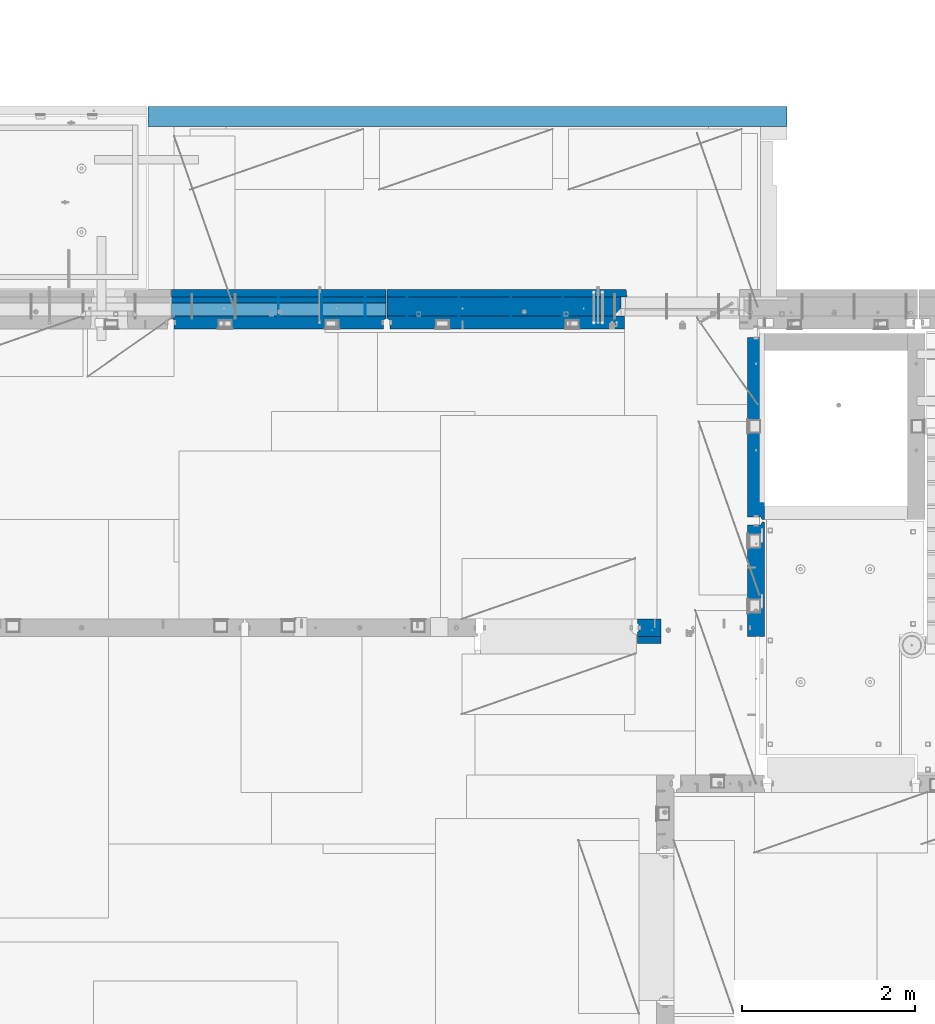
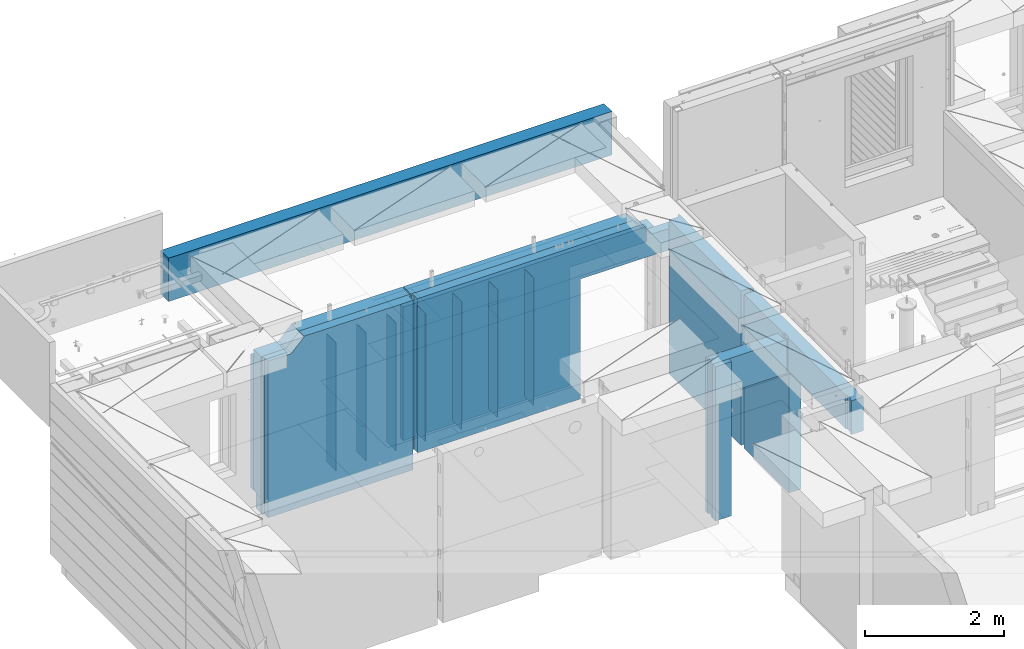
# One storey, part 216 of 325: 19 walls, 6 elements without a shape of their own.
"""IFC2X3 building model written with IfcOpenShell, lengths in millimetres."""

from ifc_helpers import new_model, si_unit, frame, origin_with_axes, place, context, subcontext, project, spatial, faceted_brep, material, type_object, element, aggregate, save


model = new_model("IFC2X3")

# Units and contexts
model_context = context("Model", 3, precision=1e-05, world=origin_with_axes())
body_context = subcontext(model_context, "Body", "Model", "MODEL_VIEW")
ifc_project = project(units=[si_unit("LENGTHUNIT", "METRE", prefix="MILLI"), si_unit("AREAUNIT", "SQUARE_METRE"), si_unit("VOLUMEUNIT", "CUBIC_METRE"), si_unit("MASSUNIT", "GRAM", prefix="KILO"), si_unit("TIMEUNIT", "SECOND"), si_unit("PLANEANGLEUNIT", "RADIAN"), si_unit("SOLIDANGLEUNIT", "STERADIAN"), si_unit("THERMODYNAMICTEMPERATUREUNIT", "DEGREE_CELSIUS"), si_unit("LUMINOUSINTENSITYUNIT", "LUMEN")], contexts=[model_context])

# Site, building, storey
site_placement = place(None, origin_with_axes())
site = spatial("IfcSite", under=ifc_project, at=site_placement, CompositionType="ELEMENT")
building_placement = place(site_placement, origin_with_axes())
building = spatial("IfcBuilding", under=site, at=building_placement, CompositionType="ELEMENT")
storey_placement = place(building_placement, origin_with_axes())
storey = spatial("IfcBuildingStorey", under=building, at=storey_placement, Name="1", CompositionType="ELEMENT", Elevation=0.0)

# Assembly, wall
assembly_1_placement = place(storey_placement, origin_with_axes())
assembly_1 = element("IfcElementAssembly", 1, at=assembly_1_placement, inside=storey, AssemblyPlace="NOTDEFINED", PredefinedType="REINFORCEMENT_UNIT")
ifc_material_1 = material(Name="CONCRETE/C25/30")
wall_type_1 = type_object("IfcWallType", PredefinedType="NOTDEFINED")
wall_1_placement = place(assembly_1_placement, frame((17710.0, 18214.9992663657, 83112.5), z_axis=(0.0, 0.0, 1.0), x_axis=(0.0, 1.0, 0.0)))
wall_1 = element("IfcWall", 2, at=wall_1_placement, type_object=wall_type_1, material=ifc_material_1, context=body_context, shape_type="Brep", body=[
    faceted_brep([(2120.00073363433, -57.0000000000036, 1357.5), (2120.00073363433, -57.0000000000036, -1357.5), (2120.00073363433, 100.0, -1357.5), (2120.00073363433, 100.0, 1357.5), (2165.00073363433, -70.0000000000036, 1357.5), (2165.00073363433, -70.0000000000036, -1357.5), (45.0, 100.0, 1357.5), (45.0, 100.0, -1357.5), (45.0, -57.0, -1357.5), (45.0, -57.0, 1357.5), (15.0, -70.0, 1357.5), (15.0, -70.0000000000036, -1357.5), (15.0, -100.0, -1357.5), (15.0, -100.0, 1357.5), (2165.00073363433, -100.0, -1357.5), (2165.00073363433, -100.0, 1357.5)], [[[0, 1, 2, 3]], [[4, 5, 1, 0]], [[6, 7, 8, 9]], [[10, 9, 8, 11]], [[12, 13, 10, 11]], [[13, 12, 14, 15]], [[3, 6, 9, 10, 13, 15, 4, 0]], [[7, 6, 3, 2]], [[14, 12, 11, 8, 7, 2, 1, 5]], [[15, 14, 5, 4]]]),
])
aggregate(assembly_1, [wall_1])

assembly_2_placement = place(storey_placement, origin_with_axes())
assembly_2 = element("IfcElementAssembly", 3, at=assembly_2_placement, inside=storey, AssemblyPlace="NOTDEFINED", PredefinedType="REINFORCEMENT_UNIT")
wall_2_placement = place(assembly_2_placement, frame((17710.0, 15080.0, 83112.5), z_axis=(0.0, 0.0, 1.0), x_axis=(0.0, 1.0, 0.0)))
wall_2 = element("IfcWall", 4, at=wall_2_placement, type_object=wall_type_1, material=ifc_material_1, context=body_context, shape_type="Brep", body=[
    faceted_brep([(1835.0, 100.0, 762.5), (1848.00000041054, 79.9999993903439, 762.5), (1951.9999991369, 80.0000000823711, 762.5), (1965.00000368528, 99.9999997455598, 762.5), (1848.00000041054, 79.9999993903439, 1357.5), (1835.0, 100.0, 1357.5), (1951.9999991369, 80.0000000823711, 1357.5), (1965.00000368528, 100.0, 1357.5), (1800.00323852539, -100.0, 762.5), (1800.00323852539, 100.0, 762.5), (1800.00323852539, 100.0, -1357.5), (1800.00323852539, -100.0, -1357.5), (3119.99926636568, -100.0, -1357.5), (3089.99926636568, 100.0, -1357.5), (3089.99926636568, -57.0, -1357.5), (3119.99926636568, -70.0, -1357.5), (3089.99926636568, -57.0, 1357.5), (3089.99926636568, 100.0, 1357.5), (3119.99926636568, -70.0, 1357.5), (3119.99926636568, -100.0, 1357.5), (164.999999999998, -99.9991455078125, 1357.5), (164.999999999998, -100.0, 762.5), (152.000000457019, -79.9991466091124, 1357.5), (152.000000457019, -79.9991466091124, 762.5), (47.9997742438973, -79.9991481948964, 1357.5), (47.9997742438973, -79.9991481948964, 762.5), (34.9997701872417, -100.0, 1357.5), (34.9997701872417, -100.0, 762.5), (0.0, -100.0, 1357.5), (0.0, -100.0, 762.5), (0.0, 100.0, 762.5), (35.0, 100.0, 762.5), (48.0, 80.0, 762.5), (152.0, 80.0, 762.5), (164.999999999996, 100.0, 762.5), (0.0, 100.0, 1357.5), (35.0, 100.0, 1357.5), (48.0, 80.0, 1357.5), (152.0, 80.0, 1357.5), (164.999999999996, 100.0, 1357.5)], [[[0, 1, 2, 3]], [[4, 1, 0, 5]], [[6, 2, 1, 4]], [[7, 3, 2, 6]], [[8, 9, 10, 11]], [[12, 11, 10, 13, 14, 15]], [[16, 14, 13, 17]], [[18, 15, 14, 16]], [[19, 12, 15, 18]], [[8, 11, 12, 19, 20, 21]], [[20, 22, 23, 21]], [[24, 25, 23, 22]], [[26, 27, 25, 24]], [[28, 29, 27, 26]], [[9, 8, 21, 23, 25, 27, 29, 30, 31, 32, 33, 34]], [[28, 35, 30, 29]], [[30, 35, 36, 31]], [[37, 32, 31, 36]], [[38, 33, 32, 37]], [[39, 34, 33, 38]], [[17, 13, 10, 9, 34, 39, 5, 0, 3, 7]], [[5, 39, 38, 37, 36, 35, 28, 26, 24, 22, 20, 19, 18, 16, 17, 7, 6, 4]]]),
])
aggregate(assembly_2, [wall_2])

assembly_3_placement = place(storey_placement, origin_with_axes())
assembly_3 = element("IfcElementAssembly", 5, at=assembly_3_placement, inside=storey, AssemblyPlace="NOTDEFINED", PredefinedType="REINFORCEMENT_UNIT")
ifc_material_2 = material(Name="CONCRETE/C30/37")
wall_3_placement = place(assembly_3_placement, frame((16339.9991042544, 16980.0, 83112.5), z_axis=(0.0, 0.0, 1.0), x_axis=(1.0, 0.0, 0.0)))
wall_3 = element("IfcWall", 6, at=wall_3_placement, type_object=wall_type_1, material=ifc_material_2, context=body_context, shape_type="Brep", body=[
    faceted_brep([(20.0000412533955, -36.0000000000036, 1357.5), (20.0000412533955, -36.0000000000036, -1357.5), (0.0, -50.0, -1357.5), (0.0, -50.0, 1357.5), (20.0000412533955, 35.9999999999964, 1357.5), (20.0000412533955, 35.9999999999964, -1357.5), (0.0, 50.0, 1357.5), (0.0, 50.0, -1357.5), (270.000743318027, 99.9999994302016, 762.5), (270.000743318027, -100.0, 762.5), (270.000743318027, -100.0, -1357.5), (270.000743318027, 100.0, -1357.5), (0.0, 100.0, -1357.5), (0.0, 100.0, 1357.5), (1205.00089558427, 100.0, 1357.5), (1205.00089558427, 99.9999953150655, 762.5), (1240.0, -72.1666661360759, 1357.5), (1240.0, -100.0, 1357.5), (1240.0, -100.0, 762.5), (1240.00086538834, -72.1666661360759, 762.5), (1205.00089574558, -57.0, 1357.5), (1205.00089574558, -57.0, 762.5), (0.0, -100.0, 1357.5), (0.0, -100.0, -1357.5)], [[[0, 1, 2, 3]], [[4, 5, 1, 0]], [[6, 7, 5, 4]], [[8, 9, 10, 11]], [[11, 12, 13, 14, 15, 8]], [[16, 17, 18, 19]], [[20, 16, 19, 21]], [[14, 20, 21, 15]], [[19, 18, 9, 8, 15, 21]], [[17, 22, 23, 10, 9, 18]], [[23, 22, 3, 2]], [[12, 11, 10, 23, 2, 1, 5, 7]], [[13, 12, 7, 6]], [[3, 22, 17, 16, 20, 14, 13, 6, 4, 0]]]),
])

assembly_4_placement = place(storey_placement, origin_with_axes())
assembly_4 = element("IfcElementAssembly", 7, at=assembly_4_placement, inside=storey, AssemblyPlace="NOTDEFINED", PredefinedType="REINFORCEMENT_UNIT")
wall_type_2 = type_object("IfcWallType", PredefinedType="NOTDEFINED")
wall_4_placement = place(assembly_4_placement, frame((13450.0, 20504.9951872276, 83112.5), z_axis=(0.0, 0.0, 1.0), x_axis=(1.0, 0.0, 0.0)))
wall_4 = element("IfcWall", 8, at=wall_4_placement, type_object=wall_type_2, material=ifc_material_1, context=body_context, shape_type="Brep", body=[
    faceted_brep([(4334.0, -50.8403744551615, 1117.5), (4334.0, -50.8403744551615, 1067.5), (4334.0, 49.1596255448385, 1067.5), (4334.0, 49.1596255448385, 1117.5), (4280.0, -50.8403744551615, 1117.5), (4280.0, 49.1596255448385, 1117.5), (4280.0, -50.8403744551615, 1127.5), (4280.0, 49.1596255448385, 1127.5), (4340.0, -50.8403744551615, 1127.5), (4339.99999999997, -50.8403744551615, 1067.5), (4339.99999999997, 49.1596255448385, 1067.5), (4340.0, 49.1596255448385, 1127.5), (4219.99999584191, -75.0, 748.653846154048), (4232.99999996855, -54.9951871385092, 748.653846154077), (4232.99999996855, -54.9951871385092, 1127.5), (4219.99999584191, -75.0, 1127.5), (4286.99999987311, -54.9951859726425, 748.65384615415), (4286.99999987311, -54.9951859726425, 1127.5), (4300.00000278436, -75.0, 748.65384615415), (4340.0, -75.0, 748.653846154208), (4340.0, -75.0, 1127.5), (4300.00000278436, -74.9970067365539, 1127.5), (4079.99976053389, -75.0, 748.653846153858), (4076.15360668774, 75.0, 748.653846153844), (4340.0, 75.0, 748.653846154208), (4079.99976053389, -75.0, 752.5), (2739.99976053389, -75.0, 752.5), (2743.84591438005, 75.0, 748.653846153844), (2739.99976053389, -75.0, -1357.5), (2743.84591438005, 75.0, -1357.5), (3699.65466308594, -75.0, 1357.5), (3699.65466308594, 75.0, 1357.5), (0.0, 75.0, 1357.5), (0.0, 45.0, 1357.5), (29.9999989126591, 32.0000004547946, 1357.5), (30.0000016637459, -75.0, 1357.5), (0.0, 75.0, -1357.5), (0.0, 45.0, -1357.5), (29.9999989126591, 32.0000004547946, -1357.5), (30.0000016637459, -75.0, -1357.5), (3930.00015258789, -75.0000000000036, 1127.5), (3930.00015258789, 74.9999999999964, 1127.5), (4340.0, 75.0, 1127.5)], [[[0, 1, 2, 3]], [[4, 0, 3, 5]], [[6, 4, 5, 7]], [[8, 9, 1, 0, 4, 6]], [[10, 2, 1, 9]], [[11, 7, 5, 3, 2, 10]], [[12, 13, 14, 15]], [[13, 16, 17, 14]], [[18, 19, 20, 21]], [[16, 18, 21, 17]], [[13, 12, 22, 23, 24, 19, 18, 16]], [[25, 23, 22]], [[26, 27, 23, 25]], [[27, 26, 28, 29]], [[30, 31, 32, 33, 34, 35]], [[32, 36, 37, 33]], [[33, 37, 38, 34]], [[36, 29, 28, 39, 38, 37]], [[34, 38, 39, 35]], [[28, 26, 25, 22, 12, 15, 40, 30, 35, 39]], [[31, 30, 40, 41]], [[24, 23, 27, 29, 36, 32, 31, 41, 42]], [[9, 8, 20, 19, 24, 42, 11, 10]], [[42, 41, 40, 15, 14, 17, 21, 20, 8, 6, 7, 11]]]),
])

assembly_5_placement = place(storey_placement, origin_with_axes())
assembly_5 = element("IfcElementAssembly", 9, at=assembly_5_placement, inside=storey, AssemblyPlace="NOTDEFINED", PredefinedType="REINFORCEMENT_UNIT")
wall_type_3 = type_object("IfcWallType", PredefinedType="NOTDEFINED")
wall_5_placement = place(assembly_5_placement, frame((10960.0, 20504.9951872276, 82977.5), z_axis=(0.0, 0.0, 1.0), x_axis=(1.0, 0.0, 0.0)))
wall_5 = element("IfcWall", 10, at=wall_5_placement, type_object=wall_type_3, material=ifc_material_1, context=body_context, shape_type="Brep", body=[
    faceted_brep([(2444.99999833626, -75.0, 1492.5), (2444.99999833626, -75.0, -1492.5), (2445.00000108732, 32.0000004548419, -1492.5), (2445.00000108732, 32.0000004548419, 1492.5), (2475.0, 45.0, 1492.5), (2475.0, 45.0, -1492.5), (0.0, 75.0, 1262.5), (0.0, 75.0, -1492.5), (0.0, 45.0, -1492.5), (0.0, 45.0, 1262.5), (30.0, 32.0, -1492.5), (30.0, 32.0, 1262.5), (30.0, -75.0, -1492.5), (30.0, -75.0, 1262.5), (415.999985106067, -75.0, 1262.5), (415.999985106067, 75.0, 1262.5), (629.999832518177, -75.0, 1482.16999816895), (629.999832518177, 75.0, 1482.16999816895), (629.999832518177, 75.0, 1492.5), (629.999832518177, -75.0, 1492.5), (2475.0, 75.0, 1492.5), (2475.0, 75.0, -1492.5)], [[[0, 1, 2, 3]], [[4, 3, 2, 5]], [[6, 7, 8, 9]], [[9, 8, 10, 11]], [[11, 10, 12, 13]], [[14, 15, 6, 9, 11, 13]], [[15, 14, 16, 17]], [[18, 17, 16, 19]], [[20, 21, 7, 6, 15, 17, 18]], [[21, 20, 4, 5]], [[1, 12, 10, 8, 7, 21, 5, 2]], [[19, 16, 14, 13, 12, 1, 0]], [[20, 18, 19, 0, 3, 4]]]),
])

# Wall
ifc_material_3 = material(Name="Undefined")
wall_type_4 = type_object("IfcWallType", PredefinedType="NOTDEFINED")
wall_6_placement = place(assembly_4_placement, frame((15480.0002441406, 20549.9951872276, 82940.0), z_axis=(0.0, 0.0, 1.0), x_axis=(0.0, 1.0, 0.0)))
wall_6 = element("IfcWall", 11, at=wall_6_placement, type_object=wall_type_4, material=ifc_material_3, Name="(PD)", context=body_context, shape_type="Brep", body=[
    faceted_brep([(0.0, 5.0, -1125.0), (0.0, 5.0, 1125.0), (280.0, 5.0, 1125.0), (280.0, 5.0, -1125.0), (0.0, -5.0, 1125.0), (280.0, -5.0, 1125.0), (0.0, -5.0, -1125.0), (280.0, -5.0, -1125.0)], [[[0, 1, 2, 3]], [[1, 4, 5, 2]], [[4, 6, 7, 5]], [[6, 0, 3, 7]], [[5, 7, 3, 2]], [[6, 4, 1, 0]]]),
])

wall_7_placement = place(assembly_4_placement, frame((14880.0002441406, 20549.9951872276, 82940.0), z_axis=(0.0, 0.0, 1.0), x_axis=(0.0, 1.0, 0.0)))
wall_7 = element("IfcWall", 12, at=wall_7_placement, type_object=wall_type_4, material=ifc_material_3, Name="(PD)", context=body_context, shape_type="Brep", body=[
    faceted_brep([(0.0, 5.0, -1125.0), (0.0, 5.0, 1125.0), (280.0, 5.0, 1125.0), (280.0, 5.0, -1125.0), (0.0, -5.0, 1125.0), (280.0, -5.0, 1125.0), (0.0, -5.0, -1125.0), (280.0, -5.0, -1125.0)], [[[0, 1, 2, 3]], [[1, 4, 5, 2]], [[4, 6, 7, 5]], [[6, 0, 3, 7]], [[5, 7, 3, 2]], [[6, 4, 1, 0]]]),
])

wall_8_placement = place(assembly_4_placement, frame((14280.0002441406, 20549.9951872276, 82940.0), z_axis=(0.0, 0.0, 1.0), x_axis=(0.0, 1.0, 0.0)))
wall_8 = element("IfcWall", 13, at=wall_8_placement, type_object=wall_type_4, material=ifc_material_3, Name="(PD)", context=body_context, shape_type="Brep", body=[
    faceted_brep([(0.0, 5.0, -1125.0), (0.0, 5.0, 1125.0), (280.0, 5.0, 1125.0), (280.0, 5.0, -1125.0), (0.0, -5.0, 1125.0), (280.0, -5.0, 1125.0), (0.0, -5.0, -1125.0), (280.0, -5.0, -1125.0)], [[[0, 1, 2, 3]], [[1, 4, 5, 2]], [[4, 6, 7, 5]], [[6, 0, 3, 7]], [[5, 7, 3, 2]], [[6, 4, 1, 0]]]),
])

wall_9_placement = place(assembly_4_placement, frame((13680.0002441406, 20549.9951872276, 82940.0), z_axis=(0.0, 0.0, 1.0), x_axis=(0.0, 1.0, 0.0)))
wall_9 = element("IfcWall", 14, at=wall_9_placement, type_object=wall_type_4, material=ifc_material_3, Name="(PD)", context=body_context, shape_type="Brep", body=[
    faceted_brep([(0.0, 5.0, -1125.0), (0.0, 5.0, 1125.0), (280.0, 5.0, 1125.0), (280.0, 5.0, -1125.0), (0.0, -5.0, 1125.0), (280.0, -5.0, 1125.0), (0.0, -5.0, -1125.0), (280.0, -5.0, -1125.0)], [[[0, 1, 2, 3]], [[1, 4, 5, 2]], [[4, 6, 7, 5]], [[6, 0, 3, 7]], [[5, 7, 3, 2]], [[6, 4, 1, 0]]]),
])

wall_10_placement = place(assembly_5_placement, frame((13195.0002441406, 20549.9951872276, 82940.0), z_axis=(0.0, 0.0, 1.0), x_axis=(0.0, 1.0, 0.0)))
wall_10 = element("IfcWall", 15, at=wall_10_placement, type_object=wall_type_4, material=ifc_material_3, Name="(PD)", context=body_context, shape_type="Brep", body=[
    faceted_brep([(0.0, 5.0, -1125.0), (0.0, 5.0, 1125.0), (280.0, 5.0, 1125.0), (280.0, 5.0, -1125.0), (0.0, -5.0, 1125.0), (280.0, -5.0, 1125.0), (0.0, -5.0, -1125.0), (280.0, -5.0, -1125.0)], [[[0, 1, 2, 3]], [[1, 4, 5, 2]], [[4, 6, 7, 5]], [[6, 0, 3, 7]], [[5, 7, 3, 2]], [[6, 4, 1, 0]]]),
])

wall_11_placement = place(assembly_5_placement, frame((12695.0002441406, 20549.9951872276, 82940.0), z_axis=(0.0, 0.0, 1.0), x_axis=(0.0, 1.0, 0.0)))
wall_11 = element("IfcWall", 16, at=wall_11_placement, type_object=wall_type_4, material=ifc_material_3, Name="(PD)", context=body_context, shape_type="Brep", body=[
    faceted_brep([(0.0, 5.0, -1125.0), (0.0, 5.0, 1125.0), (280.0, 5.0, 1125.0), (280.0, 5.0, -1125.0), (0.0, -5.0, 1125.0), (280.0, -5.0, 1125.0), (0.0, -5.0, -1125.0), (280.0, -5.0, -1125.0)], [[[0, 1, 2, 3]], [[1, 4, 5, 2]], [[4, 6, 7, 5]], [[6, 0, 3, 7]], [[5, 7, 3, 2]], [[6, 4, 1, 0]]]),
])

wall_12_placement = place(assembly_5_placement, frame((12195.0002441406, 20549.9951872276, 82940.0), z_axis=(0.0, 0.0, 1.0), x_axis=(0.0, 1.0, 0.0)))
wall_12 = element("IfcWall", 17, at=wall_12_placement, type_object=wall_type_4, material=ifc_material_3, Name="(PD)", context=body_context, shape_type="Brep", body=[
    faceted_brep([(0.0, 5.0, -1125.0), (0.0, 5.0, 1125.0), (280.0, 5.0, 1125.0), (280.0, 5.0, -1125.0), (0.0, -5.0, 1125.0), (280.0, -5.0, 1125.0), (0.0, -5.0, -1125.0), (280.0, -5.0, -1125.0)], [[[0, 1, 2, 3]], [[1, 4, 5, 2]], [[4, 6, 7, 5]], [[6, 0, 3, 7]], [[5, 7, 3, 2]], [[6, 4, 1, 0]]]),
])

ifc_material_4 = material(Name="SPU")
wall_type_5 = type_object("IfcWallType", PredefinedType="NOTDEFINED")
wall_13_placement = place(assembly_5_placement, frame((13435.0, 20654.9951872276, 81620.0000000001), z_axis=(0.0, 0.0, 1.0), x_axis=(-1.0, 3.00000001838171e-08, 0.0)))
wall_13 = element("IfcWall", 18, at=wall_13_placement, type_object=wall_type_5, material=ifc_material_4, context=body_context, shape_type="Brep", body=[
    faceted_brep([(0.0, 75.0, -135.0), (0.0, 75.0, 135.0), (2475.00000000001, 75.0, 135.0), (2475.00000000001, 75.0, -135.0), (0.0, -75.0, 135.0), (2475.00000000001, -75.0, 135.0), (0.0, -75.0, -135.0), (2475.00000000001, -75.0, -135.0)], [[[0, 1, 2, 3]], [[1, 4, 5, 2]], [[4, 6, 7, 5]], [[6, 0, 3, 7]], [[5, 7, 3, 2]], [[6, 4, 1, 0]]]),
])

wall_type_6 = type_object("IfcWallType", PredefinedType="NOTDEFINED")
wall_14_placement = place(assembly_5_placement, frame((10960.0, 20842.4951872276, 82930.0), z_axis=(0.0, 0.0, 1.0), x_axis=(1.0, 0.0, 0.0)))
wall_14 = element("IfcWall", 19, at=wall_14_placement, type_object=wall_type_6, material=ifc_material_2, context=body_context, shape_type="Brep", body=[
    faceted_brep([(2475.0, 42.5, 1060.5), (0.0, 42.5, 1060.5), (0.0, 32.5, 1062.5), (2475.0, 32.5, 1062.5), (0.0, 32.5, 1072.5), (2475.0, 32.5, 1072.5), (2475.0, 42.5, 1074.5), (0.0, 42.5, 1074.5), (2475.0, 42.5, 924.5), (2475.0, 32.5, 922.5), (0.0, 32.5, 922.5), (0.0, 42.5, 924.5), (2475.0, 32.5, 912.5), (0.0, 32.5, 912.5), (2475.0, 42.5, 910.5), (0.0, 42.5, 910.5), (2475.0, 42.5, 774.5), (0.0, 42.5, 774.5), (2475.0, 32.5, 772.5), (0.0, 32.5, 772.5), (2475.0, 32.5, 762.5), (0.0, 32.5, 762.5), (2475.0, 42.5, 760.5), (0.0, 42.5, 760.5), (2475.0, 42.5, 624.5), (0.0, 42.5, 624.5), (2475.0, 32.5, 622.5), (0.0, 32.5, 622.5), (2475.0, 32.5, 612.5), (0.0, 32.5, 612.5), (2475.0, 42.5, 610.5), (0.0, 42.5, 610.5), (2475.0, 42.5, 474.5), (0.0, 42.5, 474.5), (2475.0, 32.5, 472.5), (0.0, 32.5, 472.5), (2475.0, 32.5, 462.5), (0.0, 32.5, 462.5), (2475.0, 42.5, 460.5), (0.0, 42.5, 460.5), (2475.0, 42.5, 324.5), (0.0, 42.5, 324.5), (2475.0, 32.5, 322.5), (0.0, 32.5, 322.5), (2475.0, 32.5, 312.5), (0.0, 32.5, 312.5), (2475.0, 42.5, 310.5), (0.0, 42.5, 310.5), (2475.0, 42.5, 174.5), (0.0, 42.5, 174.5), (2475.0, 32.5, 172.5), (0.0, 32.5, 172.5), (2475.0, 32.5, 162.5), (0.0, 32.5, 162.5), (2475.0, 42.5, 160.5), (0.0, 42.5, 160.5), (2475.0, 42.5, 24.5), (0.0, 42.5, 24.5), (2475.0, 32.5, 22.5), (0.0, 32.5, 22.5), (2475.0, 32.5, 12.5), (0.0, 32.5, 12.5), (2475.0, 42.5, 10.5), (0.0, 42.5, 10.5), (2475.0, 42.5, -125.5), (0.0, 42.5, -125.5), (2475.0, 32.5, -127.5), (0.0, 32.5, -127.5), (2475.0, 32.5, -137.5), (0.0, 32.5, -137.5), (2475.0, 42.5, -139.5), (0.0, 42.5, -139.5), (2475.0, 42.5, -275.5), (0.0, 42.5, -275.5), (2475.0, 32.5, -277.5), (0.0, 32.5, -277.5), (2475.0, 32.5, -287.5), (0.0, 32.5, -287.5), (2475.0, 42.5, -289.5), (0.0, 42.5, -289.5), (2475.0, 42.5, -425.5), (0.0, 42.5, -425.5), (2475.0, 32.5, -427.5), (0.0, 32.5, -427.5), (2475.0, 32.5, -437.5), (0.0, 32.5, -437.5), (2475.0, 42.5, -439.5), (0.0, 42.5, -439.5), (2475.0, 42.5, -575.5), (0.0, 42.5, -575.5), (2475.0, 32.5, -577.5), (0.0, 32.5, -577.5), (2475.0, 32.5, -587.5), (0.0, 32.5, -587.5), (2475.0, 42.5, -589.5), (0.0, 42.5, -589.5), (2475.0, 42.5, -725.5), (0.0, 42.5, -725.5), (2475.0, 32.5, -727.5), (0.0, 32.5, -727.5), (2475.0, 32.5, -737.5), (0.0, 32.5, -737.5), (2475.0, 42.5, -739.5), (0.0, 42.5, -739.5), (2475.0, 42.5, -875.5), (0.0, 42.5, -875.5), (2475.0, 32.5, -877.5), (0.0, 32.5, -877.5), (2475.0, 32.5, -887.5), (0.0, 32.5, -887.5), (2475.0, 42.5, -889.5), (0.0, 42.5, -889.5), (2475.0, 42.5, -1025.5), (0.0, 42.5, -1025.5), (2475.0, 32.5, -1027.5), (0.0, 32.5, -1027.5), (2475.0, 32.5, -1037.5), (0.0, 32.5, -1037.5), (2475.0, 42.5, -1039.5), (0.0, 42.5, -1039.5), (2475.0, 42.5, -1175.0), (0.0, 42.5, -1175.0), (0.0, -42.5, -1175.0), (2475.0, -42.5, -1175.0), (0.0, -42.5, 1175.0), (2475.0, -42.5, 1175.0), (0.0, 42.5, 1175.0), (2475.0, 42.5, 1175.0)], [[[0, 1, 2, 3]], [[3, 2, 4, 5]], [[6, 5, 4, 7]], [[8, 9, 10, 11]], [[12, 13, 10, 9]], [[14, 15, 13, 12]], [[16, 17, 15, 14]], [[16, 18, 19, 17]], [[20, 21, 19, 18]], [[22, 23, 21, 20]], [[24, 25, 23, 22]], [[24, 26, 27, 25]], [[28, 29, 27, 26]], [[30, 31, 29, 28]], [[32, 33, 31, 30]], [[32, 34, 35, 33]], [[36, 37, 35, 34]], [[38, 39, 37, 36]], [[40, 41, 39, 38]], [[40, 42, 43, 41]], [[44, 45, 43, 42]], [[46, 47, 45, 44]], [[48, 49, 47, 46]], [[48, 50, 51, 49]], [[52, 53, 51, 50]], [[54, 55, 53, 52]], [[56, 57, 55, 54]], [[56, 58, 59, 57]], [[60, 61, 59, 58]], [[62, 63, 61, 60]], [[64, 65, 63, 62]], [[64, 66, 67, 65]], [[68, 69, 67, 66]], [[70, 71, 69, 68]], [[72, 73, 71, 70]], [[72, 74, 75, 73]], [[76, 77, 75, 74]], [[78, 79, 77, 76]], [[80, 81, 79, 78]], [[80, 82, 83, 81]], [[84, 85, 83, 82]], [[86, 87, 85, 84]], [[88, 89, 87, 86]], [[88, 90, 91, 89]], [[92, 93, 91, 90]], [[94, 95, 93, 92]], [[96, 97, 95, 94]], [[96, 98, 99, 97]], [[100, 101, 99, 98]], [[102, 103, 101, 100]], [[104, 105, 103, 102]], [[104, 106, 107, 105]], [[108, 109, 107, 106]], [[110, 111, 109, 108]], [[112, 113, 111, 110]], [[112, 114, 115, 113]], [[116, 117, 115, 114]], [[118, 119, 117, 116]], [[120, 121, 119, 118]], [[122, 121, 120, 123]], [[124, 122, 123, 125]], [[126, 124, 125, 127]], [[126, 127, 6, 7]], [[2, 1, 11, 10, 13, 15, 17, 19, 21, 23, 25, 27, 29, 31, 33, 35, 37, 39, 41, 43, 45, 47, 49, 51, 53, 55, 57, 59, 61, 63, 65, 67, 69, 71, 73, 75, 77, 79, 81, 83, 85, 87, 89, 91, 93, 95, 97, 99, 101, 103, 105, 107, 109, 111, 113, 115, 117, 119, 121, 122, 124, 126, 7, 4]], [[8, 11, 1, 0]], [[127, 125, 123, 120, 118, 116, 114, 112, 110, 108, 106, 104, 102, 100, 98, 96, 94, 92, 90, 88, 86, 84, 82, 80, 78, 76, 74, 72, 70, 68, 66, 64, 62, 60, 58, 56, 54, 52, 50, 48, 46, 44, 42, 40, 38, 36, 34, 32, 30, 28, 26, 24, 22, 20, 18, 16, 14, 12, 9, 8, 0, 3, 5, 6]]]),
])

wall_15_placement = place(assembly_4_placement, frame((13450.0, 20842.4951872276, 82930.0), z_axis=(0.0, 0.0, 1.0), x_axis=(1.0, 0.0, 0.0)))
wall_15 = element("IfcWall", 20, at=wall_15_placement, type_object=wall_type_6, material=ifc_material_2, context=body_context, shape_type="Brep", body=[
    faceted_brep([(2245.40315796376, -7.5, 162.496287248374), (2245.40315796376, -7.5, 472.496287248374), (2625.40315796376, -7.5, 472.496287248374), (2625.40315796376, -7.5, 162.496287248374), (2245.40315796376, 32.5000000000036, 162.5), (2625.40315796376, 32.5000000000036, 162.5), (2245.40315796376, 42.5, 460.5), (2245.40315796376, 32.5000000000036, 462.5), (2245.40315796376, 32.5000000000036, 472.5), (2245.40315796376, 32.5000000000036, 172.5), (2245.40315796376, 42.5, 174.5), (2245.40315796376, 42.5, 310.5), (2245.40315796376, 32.5000000000036, 312.5), (2245.40315796376, 32.5000000000036, 322.5), (2245.40315796376, 42.5, 324.5), (2625.40315796376, 32.5000000000036, 472.5), (2625.40315796376, 42.5, 460.5), (2625.40315796376, 42.5, 324.5), (2625.40315796376, 32.5000000000036, 322.5), (2625.40315796376, 32.5000000000036, 312.5), (2625.40315796376, 42.5, 310.5), (2625.40315796376, 42.5, 174.5), (2625.40315796376, 32.5000000000036, 172.5), (2625.40315796376, 32.5000000000036, 462.5), (2761.17429139664, 32.5000000000036, 762.5), (0.0, 32.5, 762.5), (0.0, 32.5, 772.5), (2761.17429044831, 32.5000000000036, 772.5), (2759.99770171037, 42.5, 760.5), (0.0, 42.5, 760.5), (2759.99770171037, 42.5, 624.5), (0.0, 42.5, 624.5), (2761.17430123561, 32.5000000000036, 622.5), (0.0, 32.5, 622.5), (2761.17430218357, 32.5000000000036, 612.5), (0.0, 32.5, 612.5), (2759.99770171037, 42.5, 610.5), (0.0, 42.5, 610.5), (2759.99770171037, 42.5, 474.5), (0.0, 42.5, 474.5), (0.0, 42.5, 1175.0), (4055.0, 42.5, 1175.0), (4055.0, 42.5000000000036, 1074.5), (0.0, 42.5, 1074.5), (0.0, -42.5, 1175.0), (4055.0, -42.5, 1175.0), (2759.99770171037, 42.5, 24.5), (0.0, 42.5, 24.5), (0.0, 42.5, 160.5), (2759.99770171037, 42.5, 160.5), (2761.17434651022, 32.5000000000036, 22.5), (0.0, 32.5, 22.5), (2761.17434745667, 32.5000000000036, 12.5), (0.0, 32.5, 12.5), (2759.99770171037, 42.5, 10.5), (0.0, 42.5, 10.5), (2759.99770171037, 42.5, -125.5), (0.0, 42.5, -125.5), (2761.17435870931, 32.5000000000036, -127.5), (0.0, 32.5, -127.5), (2761.17435965538, 32.5000000000036, -137.5), (0.0, 32.5, -137.5), (2759.99770171037, 42.5, -139.5), (0.0, 42.5, -139.5), (2759.99770171037, 42.5, -275.5), (0.0, 42.5, -275.5), (2761.1743715296, 32.5000000000036, -277.5), (0.0, 32.5, -277.5), (2761.1743724753, 32.5000000000036, -287.5), (0.0, 32.5, -287.5), (2759.99770171037, 42.5, -289.5), (0.0, 42.5, -289.5), (2759.99770171037, 42.5, -425.5), (0.0, 42.5, -425.5), (2761.17438525404, 32.5000000000036, -427.5), (0.0, 32.5, -427.5), (2761.17438619936, 32.5000000000036, -437.5), (0.0, 32.5, -437.5), (2759.99770171037, 42.5, -439.5), (0.0, 42.5, -439.5), (2759.99770171037, 42.5, -575.5), (0.0, 42.5, -575.5), (2761.17440038521, 32.5000000000036, -577.5), (0.0, 32.5, -577.5), (2761.17440133016, 32.5000000000036, -587.5), (0.0, 32.5, -587.5), (2759.99770171037, 42.5, -589.5), (0.0, 42.5, -589.5), (2759.99770171037, 42.5, -725.5), (0.0, 42.5, -725.5), (2761.17441792735, 32.5000000000036, -727.5), (0.0, 32.5, -727.5), (2761.17441887192, 32.5000000000036, -737.5), (0.0, 32.5, -737.5), (2759.99770171037, 42.5, -739.5), (0.0, 42.5, -739.5), (2759.99770171037, 42.5, -875.5), (0.0, 42.5, -875.5), (2761.17444028744, 32.5000000000036, -877.5), (0.0, 32.5, -877.5), (2761.17444123163, 32.5000000000036, -887.5), (0.0, 32.5, -887.5), (2759.99770171037, 42.5, -889.5), (0.0, 42.5, -889.5), (2759.99770171037, 42.5, -1025.5), (0.0, 42.5, -1025.5), (2761.1744754727, 32.5000000000036, -1027.5), (0.0, 32.5, -1027.5), (2761.17447641652, 32.5000000000036, -1037.5), (0.0, 32.5, -1037.5), (2759.99770171037, 42.5, -1039.5), (0.0, 42.5, -1039.5), (2759.99770171037, 42.5, -1175.0), (0.0, 42.5, -1175.0), (0.0, -42.5, -1175.0), (2769.99976053389, -42.5, -1175.0), (4055.0, -42.5, 900.0), (4049.99976053389, -42.5, 900.0), (4055.0, 0.0266143594853929, 900.0), (4049.9960350437, -42.5000000000036, 905.002857142856), (4055.0, 0.0266143594926689, 902.499862126264), (2769.99936837703, -42.5000000000036, 905.002857142856), (4055.0, 42.5, 900.0), (2759.99770171037, 42.5, 900.0), (2769.99976053389, 42.5, 900.0), (4049.99976053389, 42.5, 900.0), (4055.0, 42.5, 910.5), (4055.0, 32.5000000000036, 912.5), (4055.0, 32.5000000000036, 922.5), (4055.0, 42.5000000000036, 924.5), (4055.0, 42.5, 1060.5), (4055.0, 32.5000000000036, 1062.5), (4055.0, 32.5000000000036, 1072.5), (0.0, 42.5, 924.5), (0.0, 42.5, 1060.5), (0.0, 32.5, 1062.5), (0.0, 32.5, 1072.5), (0.0, 32.5, 922.5), (0.0, 32.5, 912.5), (0.0, 42.5, 910.5), (0.0, 42.5, 774.5), (0.0, 32.5, 472.5), (0.0, 32.5, 462.5), (0.0, 42.5, 460.5), (0.0, 42.5, 324.5), (0.0, 32.5, 322.5), (0.0, 32.5, 312.5), (0.0, 42.5, 310.5), (0.0, 42.5, 174.5), (0.0, 32.5, 172.5), (0.0, 32.5, 162.5), (2759.99770171037, 42.5, 774.5), (2761.17433570613, 32.5000000000036, 162.5), (2761.1743347593, 32.5000000000036, 172.5), (2759.99770171037, 42.5, 174.5), (2759.99770171037, 42.5, 310.5), (2761.17432429122, 32.5000000000036, 312.5), (2761.17432334401, 32.5000000000036, 322.5), (2759.99770171037, 42.5, 324.5), (2759.99770171037, 42.5, 460.5), (2761.17431313518, 32.5000000000036, 462.5), (2761.1743121876, 32.5000000000036, 472.5)], [[[0, 1, 2, 3]], [[4, 0, 3, 5]], [[6, 7, 8, 1, 0, 4, 9, 10, 11, 12, 13, 14]], [[15, 2, 1, 8]], [[16, 17, 18, 19, 20, 21, 22, 5, 3, 2, 15, 23]], [[24, 25, 26, 27]], [[28, 29, 25, 24]], [[30, 31, 29, 28]], [[32, 33, 31, 30]], [[34, 35, 33, 32]], [[36, 37, 35, 34]], [[38, 39, 37, 36]], [[40, 41, 42, 43]], [[40, 44, 45, 41]], [[46, 47, 48, 49]], [[50, 51, 47, 46]], [[52, 53, 51, 50]], [[54, 55, 53, 52]], [[56, 57, 55, 54]], [[58, 59, 57, 56]], [[60, 61, 59, 58]], [[62, 63, 61, 60]], [[64, 65, 63, 62]], [[66, 67, 65, 64]], [[68, 69, 67, 66]], [[70, 71, 69, 68]], [[72, 73, 71, 70]], [[74, 75, 73, 72]], [[76, 77, 75, 74]], [[78, 79, 77, 76]], [[80, 81, 79, 78]], [[82, 83, 81, 80]], [[84, 85, 83, 82]], [[86, 87, 85, 84]], [[88, 89, 87, 86]], [[90, 91, 89, 88]], [[92, 93, 91, 90]], [[94, 95, 93, 92]], [[96, 97, 95, 94]], [[98, 99, 97, 96]], [[100, 101, 99, 98]], [[102, 103, 101, 100]], [[104, 105, 103, 102]], [[106, 107, 105, 104]], [[108, 109, 107, 106]], [[110, 111, 109, 108]], [[112, 113, 111, 110]], [[114, 113, 112, 115]], [[116, 117, 118]], [[118, 117, 119, 120]], [[116, 45, 44, 114, 115, 121, 119, 117]], [[122, 120, 119, 121, 123, 124, 125]], [[41, 45, 116, 118, 120, 122, 126, 127, 128, 129, 130, 131, 132, 42]], [[129, 133, 134, 130]], [[130, 134, 135, 131]], [[131, 135, 136, 132]], [[42, 132, 136, 43]], [[135, 134, 133, 137, 138, 139, 140, 26, 25, 29, 31, 33, 35, 37, 39, 141, 142, 143, 144, 145, 146, 147, 148, 149, 150, 48, 47, 51, 53, 55, 57, 59, 61, 63, 65, 67, 69, 71, 73, 75, 77, 79, 81, 83, 85, 87, 89, 91, 93, 95, 97, 99, 101, 103, 105, 107, 109, 111, 113, 114, 44, 40, 43, 136]], [[129, 128, 137, 133]], [[127, 138, 137, 128]], [[126, 139, 138, 127]], [[122, 125, 124, 123, 151, 140, 139, 126]], [[27, 26, 140, 151]], [[123, 121, 115, 112, 110, 108, 106, 104, 102, 100, 98, 96, 94, 92, 90, 88, 86, 84, 82, 80, 78, 76, 74, 72, 70, 68, 66, 64, 62, 60, 58, 56, 54, 52, 50, 46, 49, 152, 153, 154, 155, 156, 157, 158, 159, 160, 161, 38, 36, 34, 32, 30, 28, 24, 27, 151]], [[160, 159, 16, 23]], [[161, 160, 23, 15]], [[141, 39, 38, 161, 15, 8]], [[142, 141, 8, 7]], [[143, 142, 7, 6]], [[144, 143, 6, 14]], [[145, 144, 14, 13]], [[146, 145, 13, 12]], [[147, 146, 12, 11]], [[148, 147, 11, 10]], [[149, 148, 10, 9]], [[150, 149, 9, 4]], [[152, 49, 48, 150, 4, 5]], [[153, 152, 5, 22]], [[154, 153, 22, 21]], [[155, 154, 21, 20]], [[156, 155, 20, 19]], [[157, 156, 19, 18]], [[158, 157, 18, 17]], [[159, 158, 17, 16]]]),
])

ifc_material_5 = material(Name="COS5gt")
wall_type_7 = type_object("IfcWallType", PredefinedType="NOTDEFINED")
wall_16_placement = place(assembly_5_placement, frame((10960.0, 20689.9951872276, 83112.5), z_axis=(0.0, 0.0, 1.0), x_axis=(1.0, 0.0, 0.0)))
wall_16 = element("IfcWall", 21, at=wall_16_placement, type_object=wall_type_7, material=ifc_material_5, context=body_context, shape_type="Brep", body=[
    faceted_brep([(2475.0, 110.0, 992.5), (0.0, 110.0, 992.5), (0.0, 90.0, 992.5), (2475.0, 90.0, 992.5), (0.0, 90.0, 1042.5), (2475.0, 90.0, 1042.5), (2475.0, 110.0, 1042.5), (0.0, 110.0, 1042.5), (415.999985106067, 110.0, 1127.5), (415.999985106067, -110.0, 1127.5), (629.999832518177, -110.0, 1347.16999816895), (629.999832518177, 110.0, 1347.16999816895), (0.0, 110.0, 1127.5), (0.0, -110.0, 1127.5), (2475.0, 110.0, -1307.5), (2475.0, 90.0, -1307.5), (0.0, 90.0, -1307.5), (0.0, 110.0, -1307.5), (2475.0, 90.0, -1357.5), (0.0, 90.0, -1357.5), (2475.0, -110.0, -1357.5), (0.0, -110.0, -1357.5), (2475.0, -110.0, 1357.5), (629.999832518177, -110.0, 1357.5), (629.999832518177, 110.0, 1357.5), (2475.0, 110.0, 1357.5)], [[[0, 1, 2, 3]], [[3, 2, 4, 5]], [[6, 5, 4, 7]], [[8, 9, 10, 11]], [[12, 13, 9, 8]], [[14, 15, 16, 17]], [[18, 19, 16, 15]], [[20, 21, 19, 18]], [[9, 13, 21, 20, 22, 23, 10]], [[24, 11, 10, 23]], [[22, 25, 24, 23]], [[12, 8, 11, 24, 25, 6, 7]], [[2, 1, 17, 16, 19, 21, 13, 12, 7, 4]], [[14, 17, 1, 0]], [[25, 22, 20, 18, 15, 14, 0, 3, 5, 6]]]),
])

aggregate(assembly_5, [wall_10, wall_11, wall_12, wall_13, wall_14, wall_16, wall_5])

wall_17_placement = place(assembly_4_placement, frame((13450.0, 20689.9951872276, 83112.5), z_axis=(0.0, 0.0, 1.0), x_axis=(1.0, 0.0, 0.0)))
wall_17 = element("IfcWall", 22, at=wall_17_placement, type_object=wall_type_7, material=ifc_material_5, context=body_context, shape_type="Brep", body=[
    faceted_brep([(3699.65466308594, 110.0, 1357.5), (3699.65466308594, -110.0, 1357.5), (3930.00015993505, -110.000000000004, 1127.49999278258), (3930.00015993505, 110.0, 1127.49999278258), (4054.99999009478, 110.0, 1127.50000589088), (4055.0, -110.0, 1127.50000589088), (4055.0, 90.0, 992.5), (0.0, 90.0, 992.5), (0.0, 90.0, 1042.5), (4055.0, 90.0, 1042.5), (4055.0, 110.0, 992.5), (0.0, 110.0, 992.5), (2699.99976053389, 110.0, -1307.5), (0.0, 110.0, -1307.5), (4055.0, 110.0, 792.5), (2699.99976053389, 109.999999999996, 792.5), (4055.0, -110.0, 792.5), (2699.99976053389, -110.000000000004, 792.5), (0.0, -110.0, -1357.5), (0.0, 90.0, -1357.5), (2699.99976053389, 90.0, -1357.5), (2699.99976053389, -110.0, -1357.5), (0.0, 90.0, -1307.5), (2699.99976053389, 90.0, -1307.5), (0.0, -110.0, 1357.5), (0.0, 110.0, 1357.5), (0.0, 110.0, 1042.5), (4055.0, 110.0, 1042.5)], [[[0, 1, 2, 3]], [[4, 3, 2, 5]], [[6, 7, 8, 9]], [[10, 11, 7, 6]], [[12, 13, 11, 10, 14, 15]], [[14, 16, 17, 15]], [[18, 19, 20, 21]], [[19, 22, 23, 20]], [[15, 17, 21, 20, 23, 12]], [[22, 13, 12, 23]], [[19, 18, 24, 25, 26, 8, 7, 11, 13, 22]], [[27, 9, 8, 26]], [[16, 14, 10, 6, 9, 27, 4, 5]], [[1, 24, 18, 21, 17, 16, 5, 2]], [[25, 24, 1, 0]], [[27, 26, 25, 0, 3, 4]]]),
])

aggregate(assembly_4, [wall_6, wall_7, wall_8, wall_9, wall_15, wall_17, wall_4])

wall_type_8 = type_object("IfcWallType", PredefinedType="NOTDEFINED")
wall_18_placement = place(assembly_3_placement, frame((16339.9991042544, 16840.0, 83112.5), z_axis=(0.0, 0.0, 1.0), x_axis=(1.0, 0.0, 0.0)))
wall_18 = element("IfcWall", 23, at=wall_18_placement, type_object=wall_type_8, material=ifc_material_2, context=body_context, shape_type="Brep", body=[
    faceted_brep([(0.0, 40.0, -1357.5), (0.0, 40.0, 1357.5), (270.000000000002, 40.0, 1357.5), (270.000000000002, 40.0, -1357.5), (0.0, -40.0, 1357.5), (270.000000000002, -40.0, 1357.5), (0.0, -40.0, -1357.5), (270.000000000002, -40.0, -1357.5)], [[[0, 1, 2, 3]], [[1, 4, 5, 2]], [[4, 6, 7, 5]], [[6, 0, 3, 7]], [[5, 7, 3, 2]], [[6, 4, 1, 0]]]),
])

aggregate(assembly_3, [wall_18, wall_3])

# Assembly, wall
assembly_6_placement = place(storey_placement, origin_with_axes())
assembly_6 = element("IfcElementAssembly", 24, at=assembly_6_placement, inside=storey, Name="Steel Assembly", AssemblyPlace="NOTDEFINED", PredefinedType="NOTDEFINED")
ifc_material_6 = material()
wall_type_9 = type_object("IfcWallType", PredefinedType="NOTDEFINED")
wall_19_placement = place(assembly_6_placement, frame((10684.9964762652, 22885.0002194537, 84357.5), z_axis=(0.0, 0.0, 1.0), x_axis=(1.0, 0.0, 0.0)))
wall_19 = element("IfcWall", 25, at=wall_19_placement, type_object=wall_type_9, material=ifc_material_6, context=body_context, shape_type="Brep", body=[
    faceted_brep([(-1.81898940354586e-12, 115.0, -382.5), (-1.81898940354586e-12, 115.0, 382.5), (7380.00352031529, 115.0, 382.5), (7380.00352031529, 115.0, -382.5), (-1.81898940354586e-12, -115.0, 382.5), (7380.00352031529, -115.0, 382.5), (-1.81898940354586e-12, -115.0, -382.5), (7380.00352031529, -115.0, -382.5)], [[[0, 1, 2, 3]], [[1, 4, 5, 2]], [[4, 6, 7, 5]], [[6, 0, 3, 7]], [[5, 7, 3, 2]], [[6, 4, 1, 0]]]),
])
aggregate(assembly_6, [wall_19])

save(model, "model.ifc")
